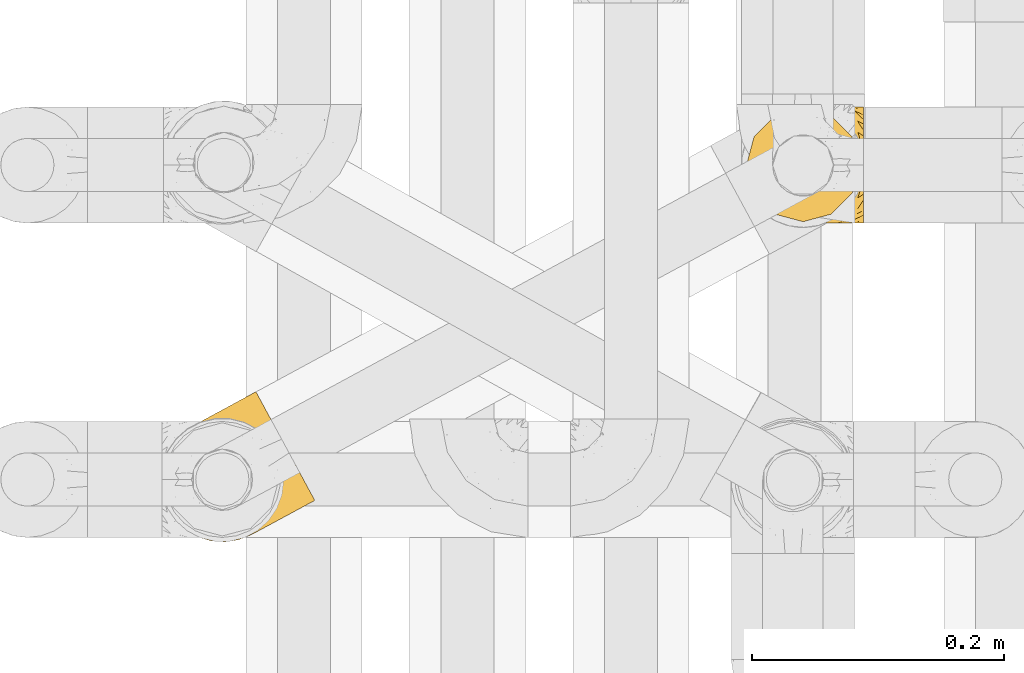
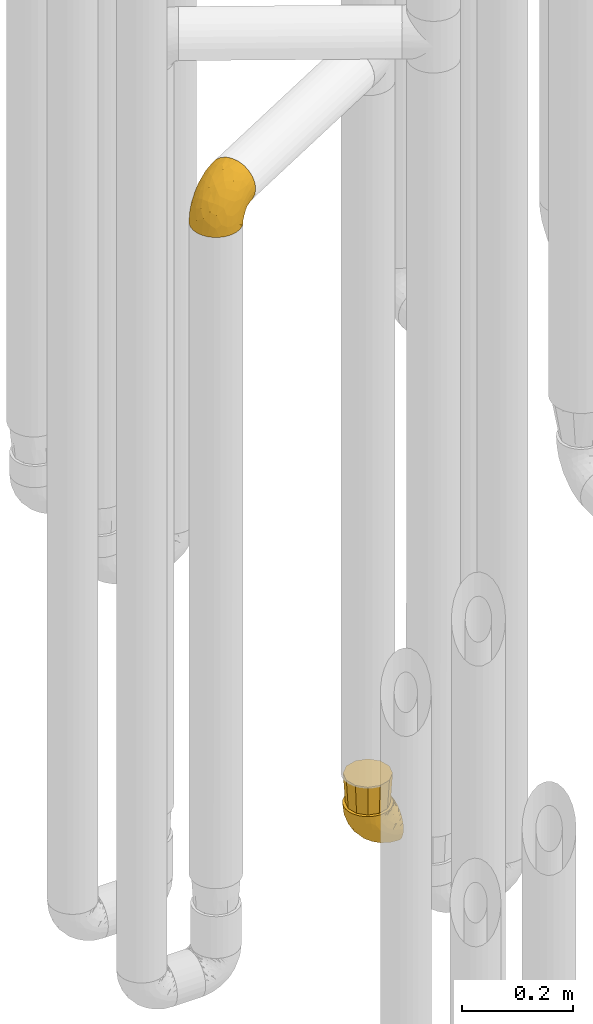
# One storey, part 161 of 827: 3 coverings.
"""IFC2X3 building model written with IfcOpenShell, lengths in millimetres."""

from ifc_helpers import new_model, entity, si_unit, converted_unit, derived_unit, direction, frame, origin, place, context, subcontext, project, spatial, faceted_brep, element, save


model = new_model("IFC2X3")

# Units and contexts
model_context = context("Model", 3, precision=0.01, world=origin(), true_north=direction((6.12303176911189e-17, 1.0)))
body_context = subcontext(model_context, "Body", "Model", "MODEL_VIEW")
ifc_project = project(units=[si_unit("LENGTHUNIT", "METRE", prefix="MILLI"), si_unit("AREAUNIT", "SQUARE_METRE"), si_unit("VOLUMEUNIT", "CUBIC_METRE"), converted_unit("PLANEANGLEUNIT", "DEGREE", entity("IfcRatioMeasure", 0.0174532925199433), si_unit("PLANEANGLEUNIT", "RADIAN"), dimensions=[0, 0, 0, 0, 0, 0, 0]), si_unit("MASSUNIT", "GRAM", prefix="KILO"), derived_unit("MASSDENSITYUNIT", [(si_unit("MASSUNIT", "GRAM", prefix="KILO"), 1), (si_unit("LENGTHUNIT", "METRE"), -3)]), derived_unit("MOMENTOFINERTIAUNIT", [(si_unit("LENGTHUNIT", "METRE"), 4)]), si_unit("TIMEUNIT", "SECOND"), si_unit("FREQUENCYUNIT", "HERTZ"), si_unit("THERMODYNAMICTEMPERATUREUNIT", "DEGREE_CELSIUS"), derived_unit("THERMALTRANSMITTANCEUNIT", [(si_unit("MASSUNIT", "GRAM", prefix="KILO"), 1), (si_unit("THERMODYNAMICTEMPERATUREUNIT", "KELVIN"), -1), (si_unit("TIMEUNIT", "SECOND"), -3)]), derived_unit("VOLUMETRICFLOWRATEUNIT", [(si_unit("LENGTHUNIT", "METRE"), 3), (si_unit("TIMEUNIT", "SECOND"), -1)]), derived_unit("MASSFLOWRATEUNIT", [(si_unit("MASSUNIT", "GRAM", prefix="KILO"), 1), (si_unit("TIMEUNIT", "SECOND"), -1)]), derived_unit("ROTATIONALFREQUENCYUNIT", [(si_unit("TIMEUNIT", "SECOND"), -1)]), si_unit("ELECTRICCURRENTUNIT", "AMPERE"), si_unit("ELECTRICVOLTAGEUNIT", "VOLT"), si_unit("POWERUNIT", "WATT"), si_unit("FORCEUNIT", "NEWTON", prefix="KILO"), si_unit("ILLUMINANCEUNIT", "LUX"), si_unit("LUMINOUSFLUXUNIT", "LUMEN"), si_unit("LUMINOUSINTENSITYUNIT", "CANDELA"), derived_unit("USERDEFINED", [(si_unit("MASSUNIT", "GRAM", prefix="KILO"), -1), (si_unit("LENGTHUNIT", "METRE"), -2), (si_unit("TIMEUNIT", "SECOND"), 3), (si_unit("LUMINOUSFLUXUNIT", "LUMEN"), 1)]), derived_unit("LINEARVELOCITYUNIT", [(si_unit("LENGTHUNIT", "METRE"), 1), (si_unit("TIMEUNIT", "SECOND"), -1)]), si_unit("PRESSUREUNIT", "PASCAL"), derived_unit("USERDEFINED", [(si_unit("LENGTHUNIT", "METRE"), -2), (si_unit("MASSUNIT", "GRAM", prefix="KILO"), 1), (si_unit("TIMEUNIT", "SECOND"), -2)]), derived_unit("LINEARFORCEUNIT", [(si_unit("MASSUNIT", "GRAM", prefix="KILO"), 1), (si_unit("LENGTHUNIT", "METRE"), 1), (si_unit("TIMEUNIT", "SECOND"), -2), (si_unit("LENGTHUNIT", "METRE"), -1)]), derived_unit("PLANARFORCEUNIT", [(si_unit("MASSUNIT", "GRAM", prefix="KILO"), 1), (si_unit("LENGTHUNIT", "METRE"), 1), (si_unit("TIMEUNIT", "SECOND"), -2), (si_unit("LENGTHUNIT", "METRE"), -2)])], contexts=[model_context])

# Site, building, storey
site_placement = place(None, origin())
site = spatial("IfcSite", under=ifc_project, at=site_placement, CompositionType="ELEMENT")
building_placement = place(site_placement, origin())
building = spatial("IfcBuilding", under=site, at=building_placement, CompositionType="ELEMENT")
storey_placement = place(building_placement, frame((0.0, 0.0, 28200.0)))
storey = spatial("IfcBuildingStorey", under=building, at=storey_placement, Name="08", CompositionType="ELEMENT", Elevation=28200.0)

# Coverings
covering_1_placement = place(storey_placement, frame((35224.34, 11504.96, 2041.34)))
element("IfcCovering", 1, at=covering_1_placement, inside=storey, Name=":ADSK_", ObjectType=":ADSK_", PredefinedType="INSULATION", context=body_context, shape_type="Brep", body=[
    faceted_brep([(63.88, 3.34, 1.59), (53.02, 1.6, 1.59), (42.03, 2.31, 1.59), (31.48, 5.45, 1.59), (21.9, 10.86, 1.6), (13.76, 18.26, 1.61), (7.47, 27.29, 1.61), (3.34, 37.5, 1.62), (1.6, 48.36, 1.64), (2.31, 59.35, 1.65), (5.45, 69.9, 1.66), (10.86, 79.48, 1.67), (18.26, 87.62, 1.67), (27.29, 93.91, 1.68), (32.6, 96.06, 1.68), (37.5, 98.04, 1.68), (42.93, 98.91, 1.68), (48.36, 99.79, 1.69), (59.35, 99.07, 1.68), (69.9, 95.93, 1.68), (79.48, 90.52, 1.68), (87.62, 83.12, 1.67), (93.91, 74.09, 1.66), (98.04, 63.88, 1.65), (99.79, 53.02, 1.64), (99.07, 42.03, 1.63), (95.93, 31.48, 1.62), (90.52, 21.9, 1.61), (86.82, 17.83, 1.61), (83.12, 13.76, 1.6), (78.8, 10.75, 1.6), (76.45, 9.11, 1.6), (74.09, 7.47, 1.6), (94.76, 89.01, 11.2), (89.12, 99.43, 16.12), (86.7, 103.9, 20.03), (84.27, 108.38, 23.94), (82.42, 111.81, 29.03), (80.56, 115.24, 34.13), (79.39, 117.39, 40.05), (78.22, 119.55, 45.98), (77.79, 120.35, 52.97), (77.61, 120.68, 55.84), (77.43, 121.01, 58.71), (78.24, 119.53, 71.43), (80.58, 115.2, 83.28), (84.3, 108.32, 93.45), (89.15, 99.37, 101.25), (94.8, 88.94, 106.15), (100.86, 77.75, 107.81), (106.91, 66.57, 106.13), (112.56, 56.15, 101.21), (117.4, 47.2, 93.39), (121.12, 40.34, 83.2), (123.45, 36.03, 71.34), (124.24, 34.57, 58.62), (123.88, 35.24, 52.89), (123.44, 36.05, 45.9), (122.27, 38.21, 39.98), (121.09, 40.38, 34.05), (119.23, 43.82, 28.97), (117.37, 47.25, 23.88), (114.95, 51.73, 19.98), (112.52, 56.21, 16.08), (106.87, 66.64, 11.18), (100.82, 77.83, 9.51), (78.11, 35.89, 91.92), (87.23, 51.12, 101.8), (62.74, 42.38, 93.11), (72.0, 62.13, 102.62), (85.46, 60.44, 104.9), (90.23, 72.0, 105.9), (44.79, 37.68, 81.86), (60.48, 30.52, 84.07), (97.92, 44.13, 97.12), (59.36, 5.81, 38.46), (67.16, 4.98, 22.17), (74.3, 9.25, 42.05), (79.99, 21.95, 75.79), (82.98, 16.29, 62.13), (102.22, 28.68, 77.72), (106.49, 26.21, 66.1), (105.05, 24.18, 54.28), (109.88, 26.8, 55.37), (114.71, 29.41, 56.47), (117.09, 30.7, 57.0), (119.47, 31.99, 57.54), (96.12, 33.62, 87.88), (56.24, 2.66, 19.41), (22.81, 24.53, 48.91), (18.92, 16.98, 26.36), (31.07, 14.87, 44.56), (77.91, 9.52, 23.42), (80.63, 10.98, 28.04), (83.35, 12.45, 32.67), (86.07, 13.92, 37.29), (88.78, 15.38, 41.92), (46.33, 2.94, 20.6), (32.54, 26.69, 63.38), (69.43, 13.99, 62.23), (26.39, 9.65, 19.94), (9.15, 28.19, 13.7), (70.08, 25.37, 80.88), (59.66, 16.44, 66.56), (51.79, 21.44, 71.12), (25.31, 36.88, 64.03), (35.64, 42.47, 75.78), (36.47, 6.27, 26.77), (74.57, 7.72, 4.31), (75.04, 7.98, 7.02), (75.99, 8.49, 12.44), (76.95, 9.0, 17.93), (48.03, 7.83, 43.42), (45.94, 13.81, 56.28), (90.6, 17.19, 54.99), (12.04, 29.73, 34.43), (92.85, 17.58, 45.01), (96.92, 19.78, 48.1), (100.98, 21.98, 51.19), (45.97, 48.05, 87.53), (44.71, 28.2, 74.58), (38.95, 19.8, 60.88), (18.67, 33.31, 49.23), (58.99, 55.09, 95.07), (83.75, 14.06, 10.28), (117.51, 31.93, 48.81), (109.03, 27.6, 45.19), (114.6, 31.19, 45.01), (100.31, 57.36, 6.22), (100.84, 48.19, 7.69), (87.61, 16.32, 21.6), (83.65, 13.31, 19.97), (110.86, 45.93, 21.04), (112.51, 40.11, 27.23), (107.12, 52.78, 14.88), (106.67, 42.18, 19.74), (102.72, 50.27, 10.97), (102.42, 62.74, 9.69), (100.67, 32.15, 20.0), (96.33, 25.49, 21.14), (97.75, 31.1, 14.16), (115.54, 39.79, 30.23), (112.35, 33.09, 36.69), (96.99, 32.65, 8.14), (99.84, 39.36, 9.96), (103.55, 32.64, 24.67), (88.77, 18.86, 11.89), (95.93, 75.18, 7.21), (97.97, 66.93, 5.38), (90.8, 18.22, 26.7), (101.95, 40.71, 13.95), (96.53, 22.29, 30.68), (104.9, 25.4, 42.91), (107.99, 31.07, 34.07), (100.45, 23.81, 36.63), (107.83, 36.21, 26.45), (93.33, 25.14, 10.1), (94.37, 24.95, 15.85), (100.72, 22.75, 42.02), (83.29, 96.78, 14.92), (69.83, 106.42, 26.51), (79.61, 103.66, 21.1), (74.2, 102.2, 19.8), (81.01, 90.2, 5.81), (42.1, 100.37, 21.69), (37.42, 98.7, 20.05), (33.82, 97.42, 28.13), (44.87, 99.97, 11.96), (68.08, 98.03, 10.02), (67.9, 115.85, 56.55), (72.67, 118.43, 57.63), (75.05, 119.72, 58.17), (60.93, 99.31, 8.21), (60.03, 100.79, 14.24), (69.32, 114.81, 45.1), (69.68, 111.89, 36.76), (75.64, 108.21, 27.3), (65.6, 109.35, 34.15), (77.03, 110.91, 30.3), (52.65, 100.35, 10.16), (53.04, 101.32, 15.93), (71.54, 116.82, 48.9), (59.17, 109.84, 42.99), (63.07, 112.06, 45.48), (38.1, 98.39, 10.37), (30.14, 95.44, 18.01), (89.06, 87.42, 9.72), (63.07, 113.24, 55.46), (58.24, 110.62, 54.36), (87.76, 84.59, 6.12), (28.23, 94.42, 7.1), (28.71, 94.67, 9.81), (29.18, 94.93, 12.52), (36.54, 98.89, 32.75), (45.44, 101.98, 26.78), (70.37, 99.05, 14.01), (39.26, 100.36, 37.38), (52.01, 104.57, 30.77), (54.55, 102.66, 21.23), (64.52, 104.79, 24.72), (55.41, 106.99, 36.7), (78.8, 94.48, 11.01), (62.51, 102.66, 20.07), (54.67, 107.8, 42.1), (50.11, 106.22, 48.18), (54.18, 108.42, 51.27), (31.1, 95.96, 23.5), (46.04, 104.02, 45.09), (41.98, 101.82, 42.0), (44.26, 102.14, 55.37), (77.94, 74.32, 104.91), (61.3, 97.93, 87.94), (42.97, 91.0, 76.01), (40.18, 80.71, 80.93), (53.35, 81.6, 91.96), (39.17, 69.81, 84.06), (13.36, 81.41, 19.24), (21.25, 89.26, 22.45), (60.74, 110.7, 66.19), (50.39, 65.18, 93.13), (71.1, 80.91, 101.82), (71.08, 93.68, 97.17), (60.48, 105.75, 77.8), (10.01, 53.79, 44.6), (5.12, 42.48, 26.38), (13.59, 41.58, 48.94), (26.79, 67.46, 71.08), (28.65, 57.87, 74.61), (17.68, 82.39, 37.89), (20.75, 48.49, 63.44), (36.64, 52.74, 81.88), (5.75, 63.04, 26.82), (8.34, 73.12, 20.67), (17.19, 66.69, 56.26), (18.44, 57.6, 60.91), (28.91, 93.03, 42.16), (26.43, 84.77, 57.12), (3.06, 52.76, 19.99), (13.45, 71.88, 43.65), (39.28, 95.95, 62.71), (26.96, 76.84, 66.61)], [[[0, 1, 2, 3, 4, 5, 6, 7, 8, 9, 10, 11, 12, 13, 14, 15, 16, 17, 18, 19, 20, 21, 22, 23, 24, 25, 26, 27, 28, 29, 30, 31, 32]], [[33, 34, 35, 36, 37, 38, 39, 40, 41, 42, 43, 44, 45, 46, 47, 48, 49, 50, 51, 52, 53, 54, 55, 56, 57, 58, 59, 60, 61, 62, 63, 64, 65]], [[66, 67, 68]], [[69, 70, 71]], [[72, 73, 68]], [[67, 66, 74]], [[75, 76, 77]], [[78, 79, 80]], [[67, 51, 50]], [[81, 82, 83, 84, 85, 86, 55]], [[52, 87, 53]], [[74, 52, 51]], [[1, 0, 88]], [[89, 90, 91]], [[77, 92, 93, 94, 95, 96]], [[55, 54, 81]], [[80, 53, 87]], [[4, 90, 5]], [[88, 76, 75]], [[97, 2, 1]], [[89, 91, 98]], [[99, 79, 78]], [[90, 4, 100]], [[74, 87, 52]], [[100, 4, 3]], [[90, 101, 5]], [[78, 102, 103]], [[102, 73, 104]], [[105, 98, 106]], [[107, 3, 2]], [[76, 32, 108, 109, 110, 111, 92]], [[107, 112, 113]], [[114, 77, 96]], [[89, 115, 90]], [[114, 96, 116, 117, 118, 82]], [[75, 97, 88]], [[119, 72, 68]], [[50, 71, 70]], [[100, 91, 90]], [[99, 77, 79]], [[102, 104, 103]], [[97, 107, 2]], [[79, 81, 80]], [[107, 97, 112]], [[68, 67, 70]], [[72, 98, 120]], [[80, 81, 54]], [[114, 81, 79]], [[53, 80, 54]], [[80, 87, 78]], [[102, 87, 66]], [[78, 103, 99]], [[3, 107, 100]], [[91, 100, 107]], [[88, 97, 1]], [[112, 97, 75]], [[99, 112, 75]], [[103, 104, 113]], [[91, 121, 98]], [[89, 105, 122, 115]], [[101, 90, 115]], [[101, 6, 5]], [[88, 0, 76]], [[32, 76, 0]], [[92, 77, 76]], [[67, 74, 51]], [[87, 74, 66]], [[81, 114, 82]], [[77, 114, 79]], [[87, 102, 78]], [[73, 102, 66]], [[68, 73, 66]], [[73, 120, 104]], [[120, 121, 104]], [[104, 121, 113]], [[121, 120, 98]], [[91, 107, 113]], [[91, 113, 121]], [[103, 113, 112]], [[106, 98, 72]], [[105, 89, 98]], [[106, 72, 119]], [[73, 72, 120]], [[68, 69, 123, 119]], [[50, 49, 71]], [[50, 70, 67]], [[112, 99, 103]], [[77, 99, 75]], [[69, 68, 70]], [[28, 124, 110]], [[84, 83, 125]], [[126, 82, 118]], [[59, 58, 127]], [[24, 128, 129]], [[130, 93, 131]], [[132, 62, 133]], [[134, 135, 136]], [[137, 65, 64]], [[64, 134, 137]], [[138, 139, 140]], [[111, 110, 124, 92]], [[134, 136, 137]], [[134, 64, 63]], [[141, 60, 142]], [[125, 58, 57]], [[143, 144, 140]], [[143, 25, 144]], [[127, 83, 82]], [[27, 124, 28]], [[108, 32, 31, 30, 29, 110, 109]], [[29, 28, 110]], [[135, 145, 138]], [[27, 146, 124]], [[57, 56, 55, 86, 85, 84]], [[147, 148, 22]], [[23, 22, 148]], [[24, 144, 25]], [[95, 94, 149]], [[23, 128, 24]], [[150, 138, 144]], [[124, 146, 131]], [[127, 58, 125]], [[151, 149, 139]], [[127, 126, 142]], [[142, 59, 127]], [[152, 142, 126]], [[153, 154, 155]], [[153, 133, 141]], [[146, 27, 26]], [[143, 156, 26]], [[157, 149, 130]], [[61, 133, 62]], [[134, 132, 135]], [[148, 128, 23]], [[65, 137, 147]], [[147, 137, 148]], [[128, 137, 136]], [[137, 128, 148]], [[128, 136, 129]], [[150, 129, 136]], [[24, 129, 144]], [[158, 152, 117]], [[152, 118, 117]], [[153, 142, 152]], [[158, 116, 154]], [[145, 151, 138]], [[153, 152, 158]], [[133, 153, 155]], [[133, 155, 132]], [[153, 141, 142]], [[135, 132, 155]], [[134, 63, 132]], [[145, 135, 155]], [[135, 138, 150]], [[155, 154, 145]], [[151, 154, 96]], [[154, 151, 145]], [[149, 94, 130]], [[82, 126, 127]], [[118, 152, 126]], [[151, 96, 95]], [[139, 149, 157]], [[151, 95, 149]], [[93, 92, 131]], [[130, 146, 156]], [[130, 94, 93]], [[84, 125, 57]], [[127, 125, 83]], [[140, 139, 157]], [[151, 139, 138]], [[140, 157, 143]], [[138, 140, 144]], [[156, 143, 157]], [[26, 25, 143]], [[130, 156, 157]], [[146, 26, 156]], [[132, 63, 62]], [[124, 131, 92]], [[130, 131, 146]], [[129, 150, 144]], [[135, 150, 136]], [[60, 141, 61]], [[60, 59, 142]], [[133, 61, 141]], [[116, 96, 154]], [[153, 158, 154]], [[158, 117, 116]], [[34, 33, 159]], [[160, 161, 162]], [[21, 20, 163]], [[164, 165, 166]], [[18, 17, 167]], [[168, 20, 19]], [[42, 41, 40, 169, 170, 171, 43]], [[172, 173, 168]], [[174, 38, 175]], [[176, 177, 178]], [[179, 164, 180]], [[40, 181, 169]], [[182, 183, 175]], [[184, 16, 185]], [[65, 147, 186]], [[187, 174, 188]], [[22, 21, 189]], [[174, 39, 38]], [[14, 13, 190, 191, 192, 15]], [[181, 40, 39]], [[193, 194, 164]], [[195, 163, 168]], [[33, 186, 159]], [[180, 173, 172]], [[196, 197, 194]], [[17, 184, 167]], [[173, 180, 198]], [[199, 197, 200]], [[192, 185, 16]], [[192, 16, 15]], [[17, 16, 184]], [[201, 159, 186]], [[195, 168, 202]], [[189, 163, 201]], [[203, 204, 182]], [[187, 181, 174]], [[160, 177, 176]], [[205, 183, 182]], [[205, 182, 204]], [[185, 206, 184]], [[206, 165, 184]], [[165, 164, 167]], [[172, 179, 180]], [[201, 195, 162]], [[176, 161, 160]], [[65, 186, 33]], [[163, 189, 21]], [[175, 177, 182]], [[174, 183, 188]], [[177, 200, 203]], [[199, 160, 162]], [[200, 207, 203]], [[175, 38, 37]], [[200, 177, 160]], [[178, 177, 175]], [[176, 35, 161]], [[34, 159, 161]], [[162, 161, 159]], [[201, 162, 159]], [[199, 162, 202]], [[197, 199, 202]], [[200, 160, 199]], [[194, 198, 180]], [[200, 197, 208]], [[188, 183, 205]], [[175, 183, 174]], [[194, 193, 196]], [[196, 208, 197]], [[198, 197, 202]], [[180, 164, 194]], [[168, 163, 20]], [[166, 165, 206]], [[166, 193, 164]], [[189, 201, 186]], [[186, 147, 189]], [[22, 189, 147]], [[174, 181, 39]], [[169, 181, 187]], [[197, 198, 194]], [[173, 202, 168]], [[202, 173, 198]], [[172, 168, 19]], [[19, 18, 172]], [[179, 172, 18]], [[18, 167, 179]], [[164, 179, 167]], [[35, 176, 36]], [[35, 34, 161]], [[184, 165, 167]], [[162, 195, 202]], [[163, 195, 201]], [[176, 178, 36]], [[37, 36, 178]], [[175, 37, 178]], [[177, 203, 182]], [[207, 200, 208]], [[207, 204, 203]], [[209, 188, 205, 204, 207, 208]], [[48, 210, 71]], [[211, 212, 213]], [[214, 213, 215]], [[216, 217, 12]], [[218, 43, 171, 170, 169, 187, 188]], [[219, 220, 214]], [[47, 46, 221]], [[210, 48, 220]], [[211, 222, 212]], [[222, 45, 44]], [[221, 220, 47]], [[47, 220, 48]], [[221, 211, 214]], [[223, 224, 225]], [[211, 46, 45]], [[226, 227, 215]], [[43, 218, 44]], [[217, 216, 228]], [[227, 229, 230]], [[13, 12, 217]], [[224, 8, 7]], [[9, 231, 10]], [[10, 232, 11]], [[233, 223, 234]], [[235, 208, 196, 193, 166, 206]], [[236, 235, 228]], [[222, 44, 218]], [[106, 230, 229]], [[224, 237, 8]], [[232, 238, 228]], [[8, 237, 9]], [[115, 224, 101]], [[239, 235, 236]], [[232, 10, 231]], [[223, 231, 237]], [[224, 7, 101]], [[223, 229, 234]], [[225, 115, 122, 105]], [[216, 11, 232]], [[209, 235, 239]], [[210, 219, 69]], [[219, 214, 215]], [[230, 119, 219]], [[209, 218, 188]], [[239, 212, 222]], [[239, 222, 218]], [[45, 222, 211]], [[236, 212, 239]], [[213, 212, 240]], [[223, 237, 224]], [[231, 9, 237]], [[238, 232, 231]], [[216, 232, 228]], [[233, 231, 223]], [[236, 238, 240]], [[115, 225, 224]], [[234, 229, 227]], [[7, 6, 101]], [[235, 209, 208]], [[218, 209, 239]], [[217, 228, 235]], [[12, 11, 216]], [[235, 206, 217]], [[217, 206, 185, 192, 191, 190, 13]], [[211, 221, 46]], [[220, 221, 214]], [[71, 210, 69]], [[71, 49, 48]], [[219, 210, 220]], [[226, 215, 213]], [[211, 213, 214]], [[226, 213, 240]], [[215, 227, 230]], [[233, 240, 238]], [[234, 227, 226]], [[233, 234, 226]], [[229, 223, 225]], [[240, 233, 226]], [[233, 238, 231]], [[225, 105, 229]], [[229, 105, 106]], [[106, 119, 230]], [[123, 69, 219, 119]], [[215, 230, 219]], [[238, 236, 228]], [[212, 236, 240]]]),
])
covering_2_placement = place(storey_placement, frame((35689.06, 11758.39, 352.2)))
element("IfcCovering", 2, at=covering_2_placement, inside=storey, Name=":ADSK_", ObjectType=":ADSK_", PredefinedType="INSULATION", context=body_context, shape_type="Brep", body=[
    faceted_brep([(37.51, 92.84, 95.81), (27.74, 89.42, 95.81), (18.98, 83.91, 95.81), (11.67, 76.59, 95.81), (6.17, 67.83, 95.8), (2.75, 58.07, 95.8), (1.6, 47.8, 95.8), (2.75, 37.51, 95.79), (6.17, 27.74, 95.79), (11.68, 18.98, 95.78), (19.0, 11.67, 95.78), (27.76, 6.17, 95.78), (37.52, 2.75, 95.78), (47.8, 1.6, 95.78), (51.94, 2.06, 95.78), (55.01, 2.41, 95.78), (58.08, 2.75, 95.78), (62.96, 4.46, 95.78), (67.85, 6.17, 95.78), (72.23, 8.93, 95.78), (76.61, 11.68, 95.78), (80.26, 15.34, 95.78), (83.92, 19.0, 95.78), (89.42, 27.76, 95.79), (91.13, 32.64, 95.79), (92.84, 37.52, 95.79), (94.0, 47.8, 95.8), (92.84, 58.08, 95.8), (91.13, 62.96, 95.8), (89.42, 67.85, 95.8), (83.91, 76.61, 95.81), (80.25, 80.26, 95.81), (76.59, 83.92, 95.81), (72.21, 86.67, 95.81), (67.83, 89.42, 95.81), (62.95, 91.13, 95.81), (58.07, 92.84, 95.81), (55.0, 93.18, 95.81), (51.94, 93.53, 95.81), (47.8, 94.0, 95.81), (95.8, 47.8, 94.0), (95.8, 35.84, 92.42), (95.8, 24.7, 87.8), (95.8, 19.92, 84.12), (95.8, 15.13, 80.45), (95.8, 11.46, 75.67), (95.8, 7.79, 70.88), (95.8, 5.49, 65.31), (95.8, 3.18, 59.74), (95.8, 2.71, 56.12), (95.8, 2.43, 54.04), (95.8, 2.16, 51.95), (95.8, 1.61, 47.78), (95.8, 3.19, 35.82), (95.8, 7.81, 24.68), (95.8, 15.16, 15.11), (95.8, 24.73, 7.78), (95.8, 35.87, 3.17), (95.8, 47.83, 1.6), (95.8, 59.79, 3.17), (95.8, 70.93, 7.79), (95.8, 80.49, 15.14), (95.8, 87.83, 24.71), (95.8, 92.44, 35.85), (95.8, 94.01, 47.81), (95.8, 93.46, 51.99), (95.8, 92.91, 56.16), (95.8, 92.43, 59.77), (95.8, 90.12, 65.34), (95.8, 87.81, 70.91), (95.8, 84.14, 75.69), (95.8, 80.47, 80.48), (95.8, 75.68, 84.14), (95.8, 70.9, 87.81), (95.8, 59.75, 92.43), (60.58, 72.01, 15.85), (74.11, 63.64, 7.0), (51.59, 59.75, 14.39), (66.69, 47.83, 6.21), (76.19, 55.2, 4.27), (84.43, 47.83, 3.39), (31.2, 63.78, 31.2), (42.88, 72.25, 26.48), (79.41, 74.21, 11.45), (60.7, 92.54, 47.67), (61.85, 94.01, 61.87), (65.75, 94.01, 59.27), (69.64, 94.01, 56.67), (73.53, 94.01, 54.07), (77.43, 94.01, 51.47), (74.59, 82.17, 19.81), (54.72, 80.36, 26.23), (64.18, 87.55, 31.59), (37.94, 79.61, 38.37), (25.89, 78.27, 51.55), (34.73, 85.02, 51.61), (42.89, 90.26, 55.98), (49.83, 93.21, 62.9), (48.58, 87.25, 41.36), (22.41, 85.55, 82.26), (78.69, 93.02, 40.9), (81.64, 89.33, 29.02), (6.22, 61.32, 74.06), (12.11, 56.87, 54.53), (14.81, 68.35, 57.98), (21.61, 65.73, 43.82), (22.41, 57.01, 38.23), (30.12, 72.17, 38.34), (10.01, 70.35, 74.77), (15.36, 78.37, 76.86), (3.39, 47.8, 84.43), (19.59, 47.82, 40.43), (30.01, 47.82, 30.01), (41.19, 93.07, 78.69), (48.54, 94.0, 92.08), (49.28, 94.0, 88.34), (49.82, 94.0, 85.62), (50.37, 94.0, 82.89), (50.91, 94.0, 80.17), (51.45, 94.0, 77.44), (31.61, 89.89, 76.38), (80.15, 94.01, 50.92), (82.88, 94.01, 50.38), (85.6, 94.01, 49.84), (88.32, 94.01, 49.3), (90.19, 94.01, 48.93), (92.06, 94.01, 48.56), (6.21, 47.81, 66.69), (54.05, 94.0, 73.55), (56.65, 94.0, 69.66), (59.25, 94.01, 65.76), (24.66, 83.71, 66.14), (40.43, 47.82, 19.59), (35.17, 55.93, 24.64), (12.9, 47.81, 53.56), (53.56, 47.83, 12.9), (85.34, 81.75, 82.82), (78.44, 86.43, 81.23), (84.37, 79.8, 86.58), (89.05, 69.84, 92.76), (82.76, 79.5, 89.7), (86.31, 88.08, 72.28), (83.73, 91.61, 64.75), (77.31, 92.94, 62.47), (87.78, 92.44, 60.65), (87.91, 93.25, 56.93), (81.29, 93.37, 58.16), (93.97, 57.25, 93.71), (70.76, 89.41, 83.42), (63.67, 92.9, 75.56), (62.62, 92.67, 79.48), (90.64, 79.58, 82.29), (84.08, 86.52, 76.26), (76.28, 86.29, 84.71), (77.45, 83.91, 90.2), (88.72, 90.95, 65.13), (71.28, 91.95, 71.72), (68.09, 91.99, 75.22), (91.07, 82.79, 78.61), (57.47, 93.16, 87.29), (70.34, 88.77, 87.93), (91.35, 73.94, 86.95), (62.99, 91.89, 86.11), (94.52, 47.8, 94.52), (76.47, 92.23, 66.25), (69.96, 88.56, 91.1), (89.86, 87.73, 71.78), (78.94, 88.34, 76.23), (73.51, 92.19, 68.6), (89.62, 71.78, 89.95), (84.09, 9.09, 76.24), (86.3, 7.52, 72.25), (91.06, 12.81, 78.59), (88.32, 1.61, 49.26), (92.06, 1.61, 48.52), (82.88, 1.61, 50.35), (85.6, 1.61, 49.81), (93.97, 38.35, 93.7), (89.63, 23.84, 89.94), (50.37, 1.6, 82.86), (49.82, 1.6, 85.58), (48.54, 1.6, 92.04), (49.28, 1.6, 88.31), (82.77, 16.1, 89.67), (70.36, 6.84, 87.91), (77.31, 2.68, 62.44), (76.47, 3.38, 66.22), (69.64, 1.61, 56.63), (65.75, 1.61, 59.24), (87.78, 3.18, 60.62), (87.91, 2.37, 56.89), (89.06, 25.77, 92.75), (90.65, 16.02, 82.27), (85.35, 13.85, 82.8), (73.53, 1.61, 54.03), (77.43, 1.61, 51.43), (81.29, 2.25, 58.13), (77.46, 11.69, 90.17), (76.29, 9.31, 84.68), (57.47, 2.43, 87.24), (63.71, 2.72, 75.56), (68.11, 3.62, 75.19), (70.77, 6.19, 83.38), (71.31, 3.67, 71.69), (78.46, 9.18, 81.21), (69.52, 6.77, 90.72), (62.64, 2.94, 79.46), (91.35, 21.66, 86.93), (59.25, 1.61, 65.73), (84.6, 16.09, 86.74), (62.98, 3.7, 86.07), (51.45, 1.6, 77.41), (54.05, 1.6, 73.52), (56.65, 1.61, 69.62), (83.73, 4.0, 64.72), (80.15, 1.61, 50.89), (88.72, 4.66, 65.1), (61.85, 1.61, 61.84), (73.56, 3.44, 68.6), (78.96, 7.27, 76.21), (91.36, 9.47, 74.02), (50.91, 1.6, 80.13), (62.87, 2.41, 49.79), (76.19, 40.46, 4.26), (73.57, 13.6, 19.94), (56.07, 11.33, 30.6), (49.77, 18.68, 25.7), (44.73, 27.28, 22.42), (60.58, 23.64, 15.84), (47.64, 3.09, 60.67), (78.32, 2.71, 40.48), (51.59, 35.9, 14.39), (74.11, 32.02, 6.99), (76.04, 6.73, 29.54), (79.41, 21.44, 11.44), (14.82, 27.25, 57.97), (6.22, 34.27, 74.05), (12.12, 38.75, 54.51), (23.51, 26.99, 43.46), (31.2, 31.85, 31.19), (34.96, 23.43, 33.26), (33.86, 6.92, 64.25), (38.94, 3.41, 74.27), (30.23, 5.85, 80.39), (20.67, 35.75, 41.66), (35.17, 39.71, 24.64), (15.85, 17.6, 73.61), (22.59, 10.39, 78.96), (21.56, 20.61, 53.68), (55.94, 5.38, 42.84), (9.19, 24.85, 79.65), (25.79, 13.88, 58.4), (41.16, 9.08, 47.1), (37.95, 16.01, 38.36)], [[[0, 1, 2, 3, 4, 5, 6, 7, 8, 9, 10, 11, 12, 13, 14, 15, 16, 17, 18, 19, 20, 21, 22, 23, 24, 25, 26, 27, 28, 29, 30, 31, 32, 33, 34, 35, 36, 37, 38, 39]], [[40, 41, 42, 43, 44, 45, 46, 47, 48, 49, 50, 51, 52, 53, 54, 55, 56, 57, 58, 59, 60, 61, 62, 63, 64, 65, 66, 67, 68, 69, 70, 71, 72, 73, 74]], [[75, 76, 77]], [[78, 79, 80]], [[77, 81, 82]], [[76, 75, 83]], [[84, 85, 86, 87, 88, 89]], [[90, 91, 92]], [[76, 60, 59]], [[93, 94, 95]], [[90, 62, 61]], [[83, 61, 60]], [[96, 97, 84]], [[98, 93, 95]], [[2, 1, 99]], [[100, 84, 89]], [[62, 101, 63]], [[4, 102, 5]], [[92, 84, 100]], [[103, 102, 104]], [[103, 105, 106]], [[93, 107, 94]], [[3, 108, 4]], [[92, 101, 90]], [[108, 3, 109]], [[102, 110, 5]], [[93, 82, 107]], [[102, 108, 104]], [[111, 106, 112]], [[109, 2, 99]], [[113, 39, 114, 115, 116, 117, 118, 119]], [[120, 0, 113]], [[100, 89, 121, 122, 123, 124, 125, 126, 64]], [[127, 102, 103]], [[97, 119, 128, 129, 130, 85]], [[99, 120, 131]], [[132, 133, 77]], [[59, 80, 79]], [[3, 2, 109]], [[98, 84, 92]], [[94, 109, 131]], [[120, 1, 0]], [[93, 91, 82]], [[104, 94, 105]], [[97, 113, 119]], [[95, 120, 96]], [[83, 90, 61]], [[91, 93, 98]], [[64, 63, 100]], [[100, 63, 101]], [[77, 76, 79]], [[133, 106, 81]], [[84, 97, 85]], [[113, 96, 120]], [[113, 97, 96]], [[39, 113, 0]], [[110, 102, 127]], [[110, 6, 5]], [[103, 111, 134, 127]], [[90, 75, 91]], [[82, 81, 107]], [[91, 75, 82]], [[77, 82, 75]], [[76, 83, 60]], [[90, 83, 75]], [[105, 107, 81]], [[94, 131, 95]], [[105, 94, 107]], [[109, 94, 104]], [[120, 95, 131]], [[98, 95, 96]], [[84, 98, 96]], [[98, 92, 91]], [[106, 105, 81]], [[103, 104, 105]], [[112, 106, 133]], [[103, 106, 111]], [[112, 133, 132]], [[81, 77, 133]], [[77, 78, 135, 132]], [[120, 99, 1]], [[109, 99, 131]], [[59, 58, 80]], [[59, 79, 76]], [[90, 101, 62]], [[100, 101, 92]], [[4, 108, 102]], [[109, 104, 108]], [[78, 77, 79]], [[136, 137, 138]], [[29, 139, 140]], [[141, 142, 143]], [[144, 145, 121]], [[146, 89, 88]], [[147, 139, 27]], [[148, 149, 150]], [[136, 151, 152]], [[147, 40, 74]], [[26, 147, 27]], [[140, 153, 154]], [[35, 116, 36]], [[73, 72, 151]], [[114, 39, 38, 37, 36, 116, 115]], [[146, 155, 144]], [[156, 85, 130]], [[157, 149, 148]], [[151, 158, 152]], [[117, 35, 159]], [[31, 154, 160]], [[161, 74, 73]], [[162, 128, 119]], [[66, 65, 64, 126, 125, 124, 123, 122, 67]], [[163, 147, 26]], [[29, 140, 30]], [[149, 129, 150]], [[139, 29, 28, 27]], [[68, 144, 69]], [[129, 128, 150]], [[164, 87, 86]], [[130, 129, 149]], [[122, 145, 67]], [[154, 153, 148]], [[162, 119, 159]], [[165, 32, 160]], [[150, 160, 148]], [[128, 162, 150]], [[32, 165, 33]], [[145, 144, 68]], [[89, 146, 144]], [[87, 164, 143]], [[166, 155, 142]], [[88, 87, 143]], [[162, 160, 150]], [[160, 32, 31]], [[154, 31, 30]], [[140, 154, 30]], [[160, 154, 148]], [[140, 137, 153]], [[157, 148, 153]], [[156, 130, 157]], [[153, 137, 157]], [[157, 137, 156]], [[167, 137, 136]], [[168, 85, 156]], [[152, 168, 167]], [[167, 168, 156]], [[164, 152, 141]], [[71, 158, 72]], [[152, 167, 136]], [[88, 142, 146]], [[144, 155, 69]], [[146, 142, 155]], [[70, 166, 71]], [[142, 141, 166]], [[70, 69, 155]], [[141, 158, 71]], [[161, 73, 151]], [[138, 137, 140]], [[161, 136, 169]], [[136, 161, 151]], [[74, 161, 169]], [[152, 158, 141]], [[151, 72, 158]], [[168, 152, 164]], [[137, 167, 156]], [[164, 86, 168]], [[85, 168, 86]], [[116, 35, 117]], [[130, 149, 157]], [[67, 145, 68]], [[121, 89, 144]], [[145, 122, 121]], [[40, 147, 163]], [[169, 147, 74]], [[159, 35, 34]], [[162, 159, 34]], [[159, 119, 118, 117]], [[139, 147, 169]], [[139, 169, 138]], [[162, 34, 33]], [[141, 143, 164]], [[88, 143, 142]], [[71, 166, 141]], [[155, 166, 70]], [[139, 138, 140]], [[169, 136, 138]], [[160, 162, 165]], [[162, 33, 165]], [[170, 171, 172]], [[173, 174, 52, 51, 50, 49, 48, 175, 176]], [[177, 178, 41]], [[179, 17, 180]], [[14, 13, 181, 182, 180, 16, 15]], [[183, 23, 22]], [[21, 20, 184]], [[185, 186, 187]], [[186, 188, 187]], [[43, 172, 44]], [[189, 190, 47]], [[25, 24, 23, 191]], [[170, 192, 193]], [[40, 163, 177]], [[194, 195, 196]], [[26, 25, 177]], [[197, 198, 183]], [[199, 17, 179]], [[47, 46, 189]], [[200, 201, 202]], [[201, 203, 204]], [[205, 206, 184]], [[207, 41, 178]], [[18, 17, 199]], [[16, 180, 17]], [[202, 201, 198]], [[208, 201, 200]], [[163, 26, 177]], [[48, 47, 190]], [[196, 195, 189]], [[197, 184, 202]], [[204, 193, 209]], [[210, 211, 212]], [[206, 212, 213]], [[205, 19, 210]], [[184, 206, 202]], [[210, 212, 206]], [[185, 194, 214]], [[189, 215, 190]], [[216, 45, 214]], [[186, 171, 170]], [[189, 216, 196]], [[197, 22, 21]], [[194, 185, 187]], [[197, 183, 22]], [[184, 197, 21]], [[197, 202, 198]], [[206, 200, 202]], [[204, 183, 198]], [[201, 208, 203]], [[203, 208, 217]], [[204, 198, 201]], [[217, 188, 218]], [[193, 219, 170]], [[171, 186, 185]], [[170, 218, 186]], [[170, 219, 218]], [[42, 207, 192]], [[171, 220, 172]], [[216, 189, 46]], [[214, 194, 196]], [[44, 220, 45]], [[214, 196, 216]], [[216, 46, 45]], [[214, 45, 220]], [[192, 43, 42]], [[204, 203, 219]], [[207, 193, 192]], [[209, 193, 178]], [[41, 207, 42]], [[193, 207, 178]], [[43, 192, 172]], [[170, 172, 192]], [[204, 219, 193]], [[219, 203, 218]], [[217, 218, 203]], [[188, 186, 218]], [[206, 213, 200]], [[208, 200, 213]], [[199, 210, 18]], [[215, 189, 195]], [[215, 175, 190]], [[175, 48, 190]], [[199, 179, 221, 211]], [[210, 199, 211]], [[25, 191, 177]], [[40, 177, 41]], [[178, 177, 191]], [[23, 183, 191]], [[209, 191, 183]], [[205, 20, 19]], [[19, 18, 210]], [[171, 185, 214]], [[172, 220, 44]], [[214, 220, 171]], [[191, 209, 178]], [[204, 209, 183]], [[206, 205, 210]], [[20, 205, 184]], [[222, 195, 194, 187, 188, 217]], [[57, 223, 80]], [[224, 225, 226]], [[226, 227, 228]], [[229, 217, 208, 213, 212, 211]], [[230, 52, 174, 173, 176, 175, 215, 195]], [[231, 232, 228]], [[231, 78, 223]], [[223, 57, 232]], [[224, 233, 225]], [[233, 54, 53]], [[234, 232, 56]], [[56, 55, 234]], [[234, 224, 228]], [[235, 236, 237]], [[224, 55, 54]], [[238, 239, 240]], [[52, 230, 53]], [[241, 242, 243]], [[239, 244, 245]], [[13, 12, 242]], [[236, 8, 7]], [[9, 246, 10]], [[10, 247, 11]], [[238, 248, 235]], [[222, 229, 249]], [[242, 211, 221, 179, 180, 182, 181, 13]], [[233, 53, 230]], [[111, 112, 244]], [[250, 8, 236]], [[247, 251, 241]], [[8, 250, 9]], [[127, 236, 110]], [[249, 229, 252]], [[247, 10, 246]], [[235, 246, 250]], [[236, 7, 110]], [[235, 244, 238]], [[237, 236, 127]], [[243, 11, 247]], [[252, 229, 241]], [[56, 232, 57]], [[222, 230, 195]], [[225, 249, 252]], [[249, 233, 230]], [[54, 233, 224]], [[231, 228, 227]], [[245, 132, 231]], [[249, 225, 233]], [[226, 225, 253]], [[235, 250, 236]], [[246, 9, 250]], [[251, 247, 246]], [[243, 247, 241]], [[248, 246, 235]], [[252, 251, 253]], [[229, 222, 217]], [[230, 222, 249]], [[7, 6, 110]], [[237, 127, 134, 111]], [[238, 244, 239]], [[224, 234, 55]], [[232, 234, 228]], [[242, 241, 229]], [[12, 11, 243]], [[211, 242, 229]], [[12, 243, 242]], [[80, 223, 78]], [[80, 58, 57]], [[231, 223, 232]], [[227, 240, 239]], [[224, 226, 228]], [[240, 226, 253]], [[227, 239, 245]], [[226, 240, 227]], [[251, 248, 253]], [[240, 253, 248]], [[244, 235, 237]], [[237, 111, 244]], [[132, 245, 112]], [[112, 245, 244]], [[135, 78, 231, 132]], [[227, 245, 231]], [[248, 238, 240]], [[246, 248, 251]], [[251, 252, 241]], [[225, 252, 253]]]),
])
covering_3_placement = place(storey_placement, frame((35690.26, 11759.57, 447.98)))
element("IfcCovering", 3, at=covering_3_placement, inside=storey, Name=":ADSK_", ObjectType=":ADSK_", PredefinedType="INSULATION", context=body_context, shape_type="Brep", body=[
    faceted_brep([(69.1, 85.57, 64.03), (59.99, 88.01, 64.03), (46.6, 91.6, 64.03), (33.21, 88.01, 64.03), (24.1, 85.57, 64.03), (15.86, 77.33, 64.03), (7.62, 69.1, 64.02), (5.18, 59.99, 64.02), (1.6, 46.6, 64.02), (5.18, 33.21, 64.01), (7.62, 24.1, 64.01), (15.86, 15.86, 64.0), (24.1, 7.62, 64.0), (33.21, 5.18, 64.0), (46.6, 1.6, 64.0), (59.99, 5.18, 64.0), (69.1, 7.62, 64.0), (77.33, 15.86, 64.0), (85.57, 24.1, 64.01), (88.01, 33.21, 64.01), (91.6, 46.6, 64.02), (88.01, 59.99, 64.02), (85.57, 69.1, 64.02), (77.33, 77.33, 64.03), (87.6, 46.62, 0.02), (84.85, 36.37, 0.01), (82.1, 26.12, 0.01), (74.6, 18.62, 0.0), (67.1, 11.11, 0.0), (56.85, 8.37, 0.0), (46.6, 5.62, 0.0), (36.35, 8.37, 0.0), (26.1, 11.11, 0.0), (18.59, 18.62, 0.0), (11.09, 26.12, 0.01), (8.34, 36.37, 0.01), (5.6, 46.62, 0.02), (8.34, 56.87, 0.02), (11.09, 67.12, 0.02), (18.59, 74.62, 0.03), (26.1, 82.13, 0.03), (36.35, 84.87, 0.03), (46.6, 87.62, 0.03), (56.85, 84.87, 0.03), (67.1, 82.13, 0.03), (74.6, 74.62, 0.03), (82.1, 67.12, 0.02), (84.85, 56.87, 0.02)], [[[0, 1, 2, 3, 4, 5, 6, 7, 8, 9, 10, 11, 12, 13, 14, 15, 16, 17, 18, 19, 20, 21, 22, 23]], [[24, 25, 26, 27, 28, 29, 30, 31, 32, 33, 34, 35, 36, 37, 38, 39, 40, 41, 42, 43, 44, 45, 46, 47]], [[34, 10, 9, 8, 36, 35]], [[11, 10, 34, 33, 32, 12]], [[31, 30, 14, 13, 12, 32]], [[28, 16, 15, 14, 30, 29]], [[17, 16, 28, 27, 26, 18]], [[25, 24, 20, 19, 18, 26]], [[46, 22, 21, 20, 24, 47]], [[23, 22, 46, 45, 44, 0]], [[43, 42, 2, 1, 0, 44]], [[40, 4, 3, 2, 42, 41]], [[5, 4, 40, 39, 38, 6]], [[37, 36, 8, 7, 6, 38]]]),
])

save(model, "model.ifc")
